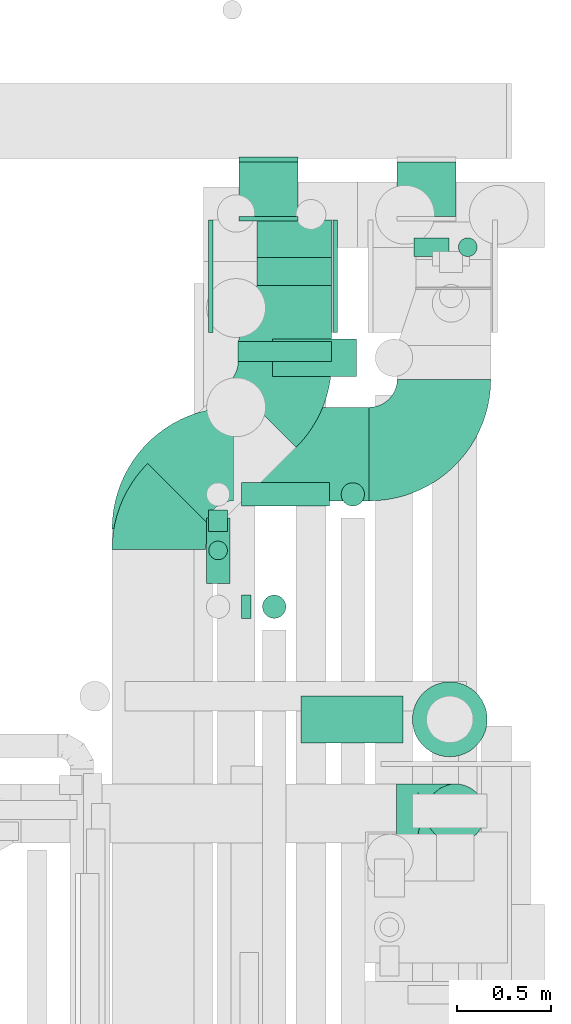
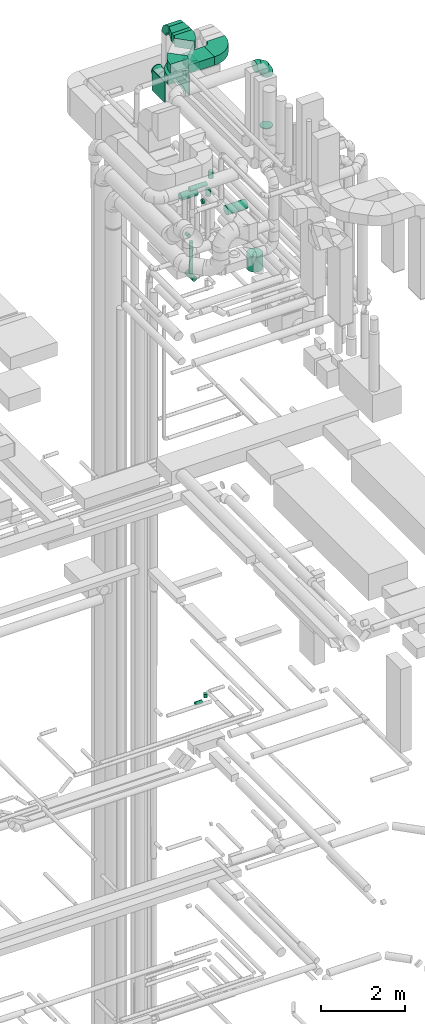
# One storey, part 311 of 337: 16 flow segments, 13 flow fittings.
"""IFC2X3 building model written with IfcOpenShell, lengths in millimetres."""

from ifc_helpers import new_model, entity, si_unit, converted_unit, derived_unit, direction, frame, frame_2d, origin, origin_2d_with_axis, place, context, subcontext, project, spatial, polyline, circle_curve, parameter, trimmed, segment, composite_curve, rectangle, circle, outline, extrude, faceted_brep, source, transform, mapped, material, type_object, type_shapes, element, save


model = new_model("IFC2X3")

# Units and contexts
model_context = context("Model", 3, precision=0.01, world=origin(), true_north=direction((6.12303176911189e-17, 1.0)))
body_context = subcontext(model_context, "Body", "Model", "MODEL_VIEW")
ifc_project = project(units=[si_unit("LENGTHUNIT", "METRE", prefix="MILLI"), si_unit("AREAUNIT", "SQUARE_METRE"), si_unit("VOLUMEUNIT", "CUBIC_METRE"), converted_unit("PLANEANGLEUNIT", "DEGREE", entity("IfcRatioMeasure", 0.0174532925199433), si_unit("PLANEANGLEUNIT", "RADIAN"), dimensions=[0, 0, 0, 0, 0, 0, 0]), si_unit("MASSUNIT", "GRAM", prefix="KILO"), derived_unit("MASSDENSITYUNIT", [(si_unit("MASSUNIT", "GRAM", prefix="KILO"), 1), (si_unit("LENGTHUNIT", "METRE"), -3)]), derived_unit("MOMENTOFINERTIAUNIT", [(si_unit("LENGTHUNIT", "METRE"), 4)]), si_unit("TIMEUNIT", "SECOND"), si_unit("FREQUENCYUNIT", "HERTZ"), si_unit("THERMODYNAMICTEMPERATUREUNIT", "DEGREE_CELSIUS"), derived_unit("THERMALTRANSMITTANCEUNIT", [(si_unit("MASSUNIT", "GRAM", prefix="KILO"), 1), (si_unit("THERMODYNAMICTEMPERATUREUNIT", "KELVIN"), -1), (si_unit("TIMEUNIT", "SECOND"), -3)]), derived_unit("VOLUMETRICFLOWRATEUNIT", [(si_unit("LENGTHUNIT", "METRE"), 3), (si_unit("TIMEUNIT", "SECOND"), -1)]), derived_unit("MASSFLOWRATEUNIT", [(si_unit("MASSUNIT", "GRAM", prefix="KILO"), 1), (si_unit("TIMEUNIT", "SECOND"), -1)]), derived_unit("ROTATIONALFREQUENCYUNIT", [(si_unit("TIMEUNIT", "SECOND"), -1)]), si_unit("ELECTRICCURRENTUNIT", "AMPERE"), si_unit("ELECTRICVOLTAGEUNIT", "VOLT"), si_unit("POWERUNIT", "WATT"), si_unit("FORCEUNIT", "NEWTON", prefix="KILO"), si_unit("ILLUMINANCEUNIT", "LUX"), si_unit("LUMINOUSFLUXUNIT", "LUMEN"), si_unit("LUMINOUSINTENSITYUNIT", "CANDELA"), derived_unit("USERDEFINED", [(si_unit("MASSUNIT", "GRAM", prefix="KILO"), -1), (si_unit("LENGTHUNIT", "METRE"), -2), (si_unit("TIMEUNIT", "SECOND"), 3), (si_unit("LUMINOUSFLUXUNIT", "LUMEN"), 1)]), derived_unit("LINEARVELOCITYUNIT", [(si_unit("LENGTHUNIT", "METRE"), 1), (si_unit("TIMEUNIT", "SECOND"), -1)]), si_unit("PRESSUREUNIT", "PASCAL"), derived_unit("USERDEFINED", [(si_unit("LENGTHUNIT", "METRE"), -2), (si_unit("MASSUNIT", "GRAM", prefix="KILO"), 1), (si_unit("TIMEUNIT", "SECOND"), -2)]), derived_unit("LINEARFORCEUNIT", [(si_unit("MASSUNIT", "GRAM", prefix="KILO"), 1), (si_unit("LENGTHUNIT", "METRE"), 1), (si_unit("TIMEUNIT", "SECOND"), -2), (si_unit("LENGTHUNIT", "METRE"), -1)]), derived_unit("PLANARFORCEUNIT", [(si_unit("MASSUNIT", "GRAM", prefix="KILO"), 1), (si_unit("LENGTHUNIT", "METRE"), 1), (si_unit("TIMEUNIT", "SECOND"), -2), (si_unit("LENGTHUNIT", "METRE"), -2)])], contexts=[model_context])

# Site, building, storey
site_placement = place(None, origin())
site = spatial("IfcSite", under=ifc_project, at=site_placement, CompositionType="ELEMENT")
building_placement = place(site_placement, origin())
building = spatial("IfcBuilding", under=site, at=building_placement, CompositionType="ELEMENT")
storey_placement = place(building_placement, origin())
storey = spatial("IfcBuildingStorey", under=building, at=storey_placement, CompositionType="ELEMENT", Elevation=0.0)

# Flow segments
duct_segment_type_1 = type_object("IfcDuctSegmentType", PredefinedType="NOTDEFINED")
flow_segment_1_placement = place(storey_placement, frame((71581.11, 15858.61, 35010.0)))
element("IfcFlowSegment", 1, at=flow_segment_1_placement, inside=storey, type_object=duct_segment_type_1, context=body_context, shape_type="SweptSolid", body=[
    extrude(rectangle(XDim=104.996866209418, YDim=499.999999999999, at=origin_2d_with_axis()), frame((250.0, 52.5, 0.0), z_axis=(0.0, 0.0, 1.0), x_axis=(0.0, 1.0, 0.0)), (0.0, 0.0, 1.0), 250.000000000004),
])
flow_segment_2_placement = place(storey_placement, frame((71557.48, 15113.0, 34600.0)))
element("IfcFlowSegment", 2, at=flow_segment_2_placement, inside=storey, type_object=duct_segment_type_1, context=body_context, shape_type="SweptSolid", body=[
    extrude(rectangle(XDim=723.625167293479, YDim=499.999999999999, at=origin_2d_with_axis()), frame((361.81, 250.0, 0.0), z_axis=(0.0, 0.0, 1.0), x_axis=(-1.0, 0.0, 0.0)), (0.0, 0.0, 1.0), 250.000000000004),
])
duct_segment_type_2 = type_object("IfcDuctSegmentType", PredefinedType="NOTDEFINED")
flow_segment_3_placement = place(storey_placement, frame((72519.33, 16416.98, 14995.4)))
element("IfcFlowSegment", 3, at=flow_segment_3_placement, inside=storey, type_object=duct_segment_type_2, context=body_context, shape_type="SweptSolid", body=[
    extrude(circle(Radius=50.0, at=origin_2d_with_axis()), frame((0.0, 51.6, 51.6), z_axis=(1.0, 0.0, 0.0), x_axis=(0.0, 1.0, 0.0)), (0.0, 0.0, 1.0), 188.24102220654),
])
flow_segment_4_placement = place(storey_placement, frame((72755.98, 16416.98, 15147.0)))
element("IfcFlowSegment", 4, at=flow_segment_4_placement, inside=storey, type_object=duct_segment_type_2, context=body_context, shape_type="SweptSolid", body=[
    extrude(circle(Radius=50.0, at=origin_2d_with_axis()), frame((51.6, 51.6, 0.0), z_axis=(0.0, 0.0, 1.0), x_axis=(0.0, 1.0, 0.0)), (0.0, 0.0, 1.0), 103.000000000003),
])
flow_segment_5_placement = place(storey_placement, frame((71583.06, 16633.61, 33390.9)))
element("IfcFlowSegment", 5, at=flow_segment_5_placement, inside=storey, type_object=duct_segment_type_2, context=body_context, shape_type="SweptSolid", body=[
    extrude(circle(Radius=157.5, at=origin_2d_with_axis()), frame((159.1, 0.0, 159.1), z_axis=(0.0, 1.0, 0.0), x_axis=(1.0, 0.0, 0.0)), (0.0, 0.0, 1.0), 289.999999999986),
])
flow_segment_6_placement = place(storey_placement, frame((72427.44, 16633.61, 33390.9)))
element("IfcFlowSegment", 6, at=flow_segment_6_placement, inside=storey, type_object=duct_segment_type_2, context=body_context, shape_type="SweptSolid", body=[
    extrude(circle(Radius=157.5, at=origin_2d_with_axis()), frame((159.1, 0.0, 159.1), z_axis=(0.0, 1.0, 0.0), x_axis=(1.0, 0.0, 0.0)), (0.0, 0.0, 1.0), 289.999999999977),
])
flow_segment_7_placement = place(storey_placement, frame((71916.81, 13819.26, 31073.4)))
element("IfcFlowSegment", 7, at=flow_segment_7_placement, inside=storey, type_object=duct_segment_type_2, context=body_context, shape_type="SweptSolid", body=[
    extrude(circle(Radius=125.0, at=origin_2d_with_axis()), frame((0.0, 126.6, 126.6), z_axis=(1.0, 0.0, 0.0), x_axis=(0.0, -1.0, 0.0)), (0.0, 0.0, 1.0), 545.000000000041),
])
flow_segment_8_placement = place(storey_placement, frame((72129.7, 15083.65, 31325.0)))
element("IfcFlowSegment", 8, at=flow_segment_8_placement, inside=storey, type_object=duct_segment_type_2, context=body_context, shape_type="SweptSolid", body=[
    extrude(circle(Radius=62.5, at=origin_2d_with_axis()), frame((64.1, 64.1, 0.0), z_axis=(0.0, 0.0, 1.0), x_axis=(-1.0, 0.0, 0.0)), (0.0, 0.0, 1.0), 199.999999999994),
])
flow_segment_9_placement = place(storey_placement, frame((71598.8, 15083.65, 31135.9)))
element("IfcFlowSegment", 9, at=flow_segment_9_placement, inside=storey, type_object=duct_segment_type_2, context=body_context, shape_type="SweptSolid", body=[
    extrude(circle(Radius=62.5, at=origin_2d_with_axis()), frame((0.0, 64.1, 64.1), z_axis=(1.0, 0.0, 0.0), x_axis=(0.0, 1.0, 0.0)), (0.0, 0.0, 1.0), 470.000000000014),
])
flow_segment_10_placement = place(storey_placement, frame((71409.7, 14672.75, 28835.9)))
element("IfcFlowSegment", 10, at=flow_segment_10_placement, inside=storey, type_object=duct_segment_type_2, context=body_context, shape_type="SweptSolid", body=[
    extrude(circle(Radius=62.5, at=origin_2d_with_axis()), frame((64.1, 0.0, 64.1), z_axis=(0.0, 1.0, 0.0), x_axis=(-1.0, 0.0, 0.0)), (0.0, 0.0, 1.0), 350.000000000018),
])
flow_segment_11_placement = place(storey_placement, frame((71598.8, 14483.65, 31135.9)))
element("IfcFlowSegment", 11, at=flow_segment_11_placement, inside=storey, type_object=duct_segment_type_2, context=body_context, shape_type="SweptSolid", body=[
    extrude(circle(Radius=62.5, at=origin_2d_with_axis()), frame((0.0, 64.1, 64.1), z_axis=(1.0, 0.0, 0.0), x_axis=(0.0, -1.0, 0.0)), (0.0, 0.0, 1.0), 50.0000000000146),
])
flow_segment_12_placement = place(storey_placement, frame((71709.7, 14483.65, 31325.0)))
element("IfcFlowSegment", 12, at=flow_segment_12_placement, inside=storey, type_object=duct_segment_type_2, context=body_context, shape_type="SweptSolid", body=[
    extrude(circle(Radius=62.5, at=origin_2d_with_axis()), frame((64.1, 64.1, 0.0), z_axis=(0.0, 0.0, 1.0), x_axis=(0.0, -1.0, 0.0)), (0.0, 0.0, 1.0), 189.999999999991),
])
flow_segment_13_placement = place(storey_placement, frame((72510.22, 13744.26, 29250.0)))
element("IfcFlowSegment", 13, at=flow_segment_13_placement, inside=storey, type_object=duct_segment_type_2, context=body_context, shape_type="SweptSolid", body=[
    extrude(circle(Radius=200.0, at=origin_2d_with_axis()), frame((201.6, 201.6, 0.0), z_axis=(0.0, 0.0, 1.0), x_axis=(0.0, -1.0, 0.0)), (0.0, 0.0, 1.0), 440.000000000026),
])
flow_segment_14_placement = place(storey_placement, frame((71422.2, 14796.98, 28982.5)))
element("IfcFlowSegment", 14, at=flow_segment_14_placement, inside=storey, type_object=duct_segment_type_2, context=body_context, shape_type="SweptSolid", body=[
    extrude(circle(Radius=50.0, at=origin_2d_with_axis()), frame((51.6, 51.6, 0.0), z_axis=(0.0, 0.0, 1.0), x_axis=(0.0, 1.0, 0.0)), (0.0, 0.0, 1.0), 917.499999999921),
])
flow_segment_15_placement = place(storey_placement, frame((71422.2, 14948.58, 29948.4)))
element("IfcFlowSegment", 15, at=flow_segment_15_placement, inside=storey, type_object=duct_segment_type_2, context=body_context, shape_type="SweptSolid", body=[
    extrude(circle(Radius=50.0, at=origin_2d_with_axis()), frame((51.6, 0.0, 51.6), z_axis=(0.0, 1.0, 0.0), x_axis=(-1.0, 0.0, 0.0)), (0.0, 0.0, 1.0), 116.667364066058),
])
flow_segment_16_placement = place(storey_placement, frame((71765.11, 15776.15, 30373.4)))
element("IfcFlowSegment", 16, at=flow_segment_16_placement, inside=storey, type_object=duct_segment_type_2, context=body_context, shape_type="SweptSolid", body=[
    extrude(circle(Radius=100.0, at=origin_2d_with_axis()), frame((0.0, 101.6, 101.6), z_axis=(1.0, 0.0, 0.0), x_axis=(0.0, 1.0, 0.0)), (0.0, 0.0, 1.0), 448.687977067073),
])

# Flow fittings
ifc_material = material()
duct_fitting_type_1 = type_object("IfcDuctFittingType", PredefinedType="NOTDEFINED", material=ifc_material)
shared_shape_1 = source(origin(), body_context, "Body", "SweptSolid", [
    extrude(rectangle(XDim=200.0, YDim=26.096, at=origin_2d_with_axis()), frame((6.95, 0.0, -200.0), z_axis=(0.0, 0.0, 1.0), x_axis=(0.0, -1.0, 0.0)), (0.0, 0.0, 1.0), 400.0),
])
type_shapes(duct_fitting_type_1, [shared_shape_1])
flow_fitting_1_placement = place(storey_placement, frame((71881.11, 16513.61, 33850.0), z_axis=(1.0, 0.0, 0.0), x_axis=(0.0, 0.0, 1.0)))
element("IfcFlowFitting", 17, at=flow_fitting_1_placement, inside=storey, type_object=duct_fitting_type_1, material=ifc_material, context=body_context, shape_type="MappedRepresentation", body=[
    mapped(shared_shape_1, transform((0.0, 0.0, 0.0), scale=1.0)),
])
duct_fitting_type_2 = type_object("IfcDuctFittingType", PredefinedType="NOTDEFINED", material=ifc_material)
shared_shape_2 = source(origin(), body_context, "Body", "SweptSolid", [
    extrude(rectangle(XDim=24.9999999999999, YDim=600.0, at=origin_2d_with_axis()), frame((12.5, 0.0, -300.0)), (0.0, 0.0, 1.0), 600.0),
])
type_shapes(duct_fitting_type_2, [shared_shape_2])
flow_fitting_2_placement = place(storey_placement, frame((72087.1, 16313.61, 33550.0)))
element("IfcFlowFitting", 18, at=flow_fitting_2_placement, inside=storey, type_object=duct_fitting_type_2, material=ifc_material, context=body_context, shape_type="MappedRepresentation", body=[
    mapped(shared_shape_2, transform((0.0, 0.0, 0.0), scale=1.0)),
])
flow_fitting_3_placement = place(storey_placement, frame((71447.1, 16313.61, 33550.0), z_axis=(0.0, 0.0, 1.0), x_axis=(-1.0, 0.0, 0.0)))
element("IfcFlowFitting", 19, at=flow_fitting_3_placement, inside=storey, type_object=duct_fitting_type_2, material=ifc_material, context=body_context, shape_type="MappedRepresentation", body=[
    mapped(shared_shape_2, transform((0.0, 0.0, 0.0), scale=1.0)),
])
duct_fitting_type_3 = type_object("IfcDuctFittingType", PredefinedType="NOTDEFINED", material=ifc_material)
shared_shape_3 = source(origin(), body_context, "Body", "Brep", [
    faceted_brep([(-315.0, 0.0, -157.5), (-315.0, -40.76, -152.13), (-315.0, -78.75, -136.4), (-315.0, -111.37, -111.37), (-315.0, -136.4, -78.75), (-315.0, -152.13, -40.76), (-315.0, -157.5, 0.0), (-315.0, -152.13, 40.76), (-315.0, -136.4, 78.75), (-315.0, -111.37, 111.37), (-315.0, -78.75, 136.4), (-315.0, -40.76, 152.13), (-315.0, 0.0, 157.5), (-315.0, 40.76, 152.13), (-315.0, 78.75, 136.4), (-315.0, 111.37, 111.37), (-315.0, 136.4, 78.75), (-315.0, 152.13, 40.76), (-315.0, 157.5, 0.0), (-315.0, 152.13, -40.76), (-315.0, 136.4, -78.75), (-315.0, 111.37, -111.37), (-315.0, 78.75, -136.4), (-315.0, 40.76, -152.13), (-241.52, 40.76, 152.13), (-251.7, 78.75, 136.4), (-230.6, 0.0, 157.5), (-260.44, 111.37, 111.37), (-271.36, 152.13, 40.76), (-272.8, 157.5, 0.0), (-267.14, 136.4, 78.75), (-267.14, 136.4, -78.75), (-260.44, 111.37, -111.37), (-271.36, 152.13, -40.76), (-241.52, 40.76, -152.13), (-230.6, 0.0, -157.5), (-251.7, 78.75, -136.4), (-219.67, -40.76, -152.13), (-209.5, -78.75, -136.4), (-200.75, -111.37, -111.37), (-194.05, -136.4, -78.75), (-189.83, -152.13, -40.76), (-188.39, -157.5, 0.0), (-189.83, -152.13, 40.76), (-194.05, -136.4, 78.75), (-200.75, -111.37, 111.37), (-209.5, -78.75, 136.4), (-219.67, -40.76, 152.13), (-114.25, 114.25, 152.13), (-142.05, 142.05, 136.4), (-84.4, 84.4, 157.5), (-165.93, 165.93, 111.37), (-184.25, 184.25, 78.75), (-195.77, 195.77, 40.76), (-199.7, 199.7, 0.0), (-195.77, 195.77, -40.76), (-184.25, 184.25, -78.75), (-165.93, 165.93, -111.37), (-114.25, 114.25, -152.13), (-84.4, 84.4, -157.5), (-142.05, 142.05, -136.4), (-54.56, 54.56, -152.13), (-26.75, 26.75, -136.4), (-2.88, 2.88, -111.37), (15.45, -15.45, -78.75), (26.97, -26.97, -40.76), (30.89, -30.89, 0.0), (26.97, -26.97, 40.76), (15.45, -15.45, 78.75), (-2.88, 2.88, 111.37), (-26.75, 26.75, 136.4), (-54.56, 54.56, 152.13), (-40.76, 241.52, 152.13), (-78.75, 251.7, 136.4), (0.0, 230.6, 157.5), (-111.37, 260.44, 111.37), (-136.4, 267.14, 78.75), (-152.13, 271.36, 40.76), (-157.5, 272.8, 0.0), (-152.13, 271.36, -40.76), (-136.4, 267.14, -78.75), (-111.37, 260.44, -111.37), (-40.76, 241.52, -152.13), (0.0, 230.6, -157.5), (-78.75, 251.7, -136.4), (40.76, 219.67, -152.13), (78.75, 209.5, -136.4), (111.37, 200.75, -111.37), (136.4, 194.05, -78.75), (152.13, 189.83, -40.76), (157.5, 188.39, 0.0), (152.13, 189.83, 40.76), (136.4, 194.05, 78.75), (111.37, 200.75, 111.37), (78.75, 209.5, 136.4), (40.76, 219.67, 152.13), (-40.76, 315.0, -152.13), (-78.75, 315.0, -136.4), (-111.37, 315.0, -111.37), (-136.4, 315.0, -78.75), (-152.13, 315.0, -40.76), (-157.5, 315.0, 0.0), (-152.13, 315.0, 40.76), (-136.4, 315.0, 78.75), (-111.37, 315.0, 111.37), (-78.75, 315.0, 136.4), (-40.76, 315.0, 152.13), (0.0, 315.0, 157.5), (40.76, 315.0, 152.13), (78.75, 315.0, 136.4), (111.37, 315.0, 111.37), (136.4, 315.0, 78.75), (152.13, 315.0, 40.76), (157.5, 315.0, 0.0), (152.13, 315.0, -40.76), (136.4, 315.0, -78.75), (111.37, 315.0, -111.37), (78.75, 315.0, -136.4), (40.76, 315.0, -152.13), (0.0, 315.0, -157.5)], [[[0, 1, 2, 3, 4, 5, 6, 7, 8, 9, 10, 11, 12, 13, 14, 15, 16, 17, 18, 19, 20, 21, 22, 23]], [[24, 25, 14, 13]], [[26, 24, 13, 12]], [[14, 25, 27, 15]], [[28, 29, 18, 17]], [[30, 28, 17, 16]], [[15, 27, 30, 16]], [[20, 31, 32, 21]], [[33, 31, 20, 19]], [[18, 29, 33, 19]], [[34, 35, 0, 23]], [[36, 34, 23, 22]], [[32, 36, 22, 21]], [[1, 0, 35, 37]], [[2, 1, 37, 38]], [[38, 39, 3, 2]], [[5, 4, 40, 41]], [[6, 5, 41, 42]], [[39, 40, 4, 3]], [[6, 42, 43, 7]], [[7, 43, 44, 8]], [[8, 44, 45, 9]], [[9, 45, 46, 10]], [[10, 46, 47, 11]], [[26, 12, 11, 47]], [[48, 49, 25, 24]], [[50, 48, 24, 26]], [[27, 25, 49, 51]], [[52, 53, 28, 30]], [[51, 52, 30, 27]], [[29, 28, 53, 54]], [[55, 56, 31, 33]], [[54, 55, 33, 29]], [[32, 31, 56, 57]], [[58, 59, 35, 34]], [[60, 58, 34, 36]], [[57, 60, 36, 32]], [[37, 35, 59, 61]], [[38, 37, 61, 62]], [[39, 38, 62, 63]], [[41, 40, 64, 65]], [[42, 41, 65, 66]], [[63, 64, 40, 39]], [[43, 42, 66, 67]], [[44, 43, 67, 68]], [[68, 69, 45, 44]], [[46, 45, 69, 70]], [[47, 46, 70, 71]], [[26, 47, 71, 50]], [[72, 73, 49, 48]], [[74, 72, 48, 50]], [[51, 49, 73, 75]], [[76, 77, 53, 52]], [[75, 76, 52, 51]], [[54, 53, 77, 78]], [[79, 80, 56, 55]], [[78, 79, 55, 54]], [[57, 56, 80, 81]], [[82, 83, 59, 58]], [[84, 82, 58, 60]], [[81, 84, 60, 57]], [[61, 59, 83, 85]], [[62, 61, 85, 86]], [[63, 62, 86, 87]], [[65, 64, 88, 89]], [[66, 65, 89, 90]], [[87, 88, 64, 63]], [[67, 66, 90, 91]], [[68, 67, 91, 92]], [[92, 93, 69, 68]], [[70, 69, 93, 94]], [[71, 70, 94, 95]], [[50, 71, 95, 74]], [[96, 97, 98, 99, 100, 101, 102, 103, 104, 105, 106, 107, 108, 109, 110, 111, 112, 113, 114, 115, 116, 117, 118, 119]], [[106, 105, 73, 72]], [[107, 106, 72, 74]], [[75, 73, 105, 104]], [[77, 76, 103, 102]], [[78, 77, 102, 101]], [[104, 103, 76, 75]], [[78, 101, 100, 79]], [[79, 100, 99, 80]], [[98, 81, 80, 99]], [[84, 97, 96, 82]], [[82, 96, 119, 83]], [[97, 84, 81, 98]], [[83, 119, 118, 85]], [[85, 118, 117, 86]], [[116, 87, 86, 117]], [[88, 115, 114, 89]], [[89, 114, 113, 90]], [[115, 88, 87, 116]], [[91, 90, 113, 112]], [[92, 91, 112, 111]], [[111, 110, 93, 92]], [[95, 94, 109, 108]], [[74, 95, 108, 107]], [[110, 109, 94, 93]]]),
])
type_shapes(duct_fitting_type_3, [shared_shape_3])
flow_fitting_4_placement = place(storey_placement, frame((72743.11, 13443.57, 35520.0), z_axis=(0.0, 1.0, 0.0), x_axis=(1.0, 0.0, 0.0)))
element("IfcFlowFitting", 20, at=flow_fitting_4_placement, inside=storey, type_object=duct_fitting_type_3, material=ifc_material, context=body_context, shape_type="MappedRepresentation", body=[
    mapped(shared_shape_3, transform((0.0, 0.0, 0.0), scale=1.0)),
])
duct_fitting_type_4 = type_object("IfcDuctFittingType", PredefinedType="NOTDEFINED", material=ifc_material)
shared_shape_4 = source(origin(), body_context, "Body", "Brep", [
    faceted_brep([(20.0, 40.76, -152.13), (20.0, 78.75, -136.4), (20.0, 111.37, -111.37), (20.0, 136.4, -78.75), (20.0, 152.13, -40.76), (20.0, 157.5, 0.0), (20.0, 152.13, 40.76), (20.0, 136.4, 78.75), (20.0, 111.37, 111.37), (20.0, 78.75, 136.4), (20.0, 40.76, 152.13), (20.0, 0.0, 157.5), (20.0, -40.76, 152.13), (20.0, -78.75, 136.4), (20.0, -111.37, 111.37), (20.0, -136.4, 78.75), (20.0, -152.13, 40.76), (20.0, -157.5, 0.0), (20.0, -152.13, -40.76), (20.0, -136.4, -78.75), (20.0, -111.37, -111.37), (20.0, -78.75, -136.4), (20.0, -40.76, -152.13), (20.0, 0.0, -157.5), (0.0, 0.0, 157.5), (0.0, 40.76, 152.13), (-6.1, 40.76, 152.13), (-6.1, 0.0, 157.5), (0.0, 78.75, 136.4), (-6.1, 78.75, 136.4), (0.0, 111.37, 111.37), (-6.1, 111.37, 111.37), (0.0, 136.4, 78.75), (0.0, 152.13, 40.76), (-6.1, 152.13, 40.76), (-6.1, 136.4, 78.75), (0.0, 157.5, 0.0), (-6.1, 157.5, 0.0), (0.0, 152.13, -40.76), (-6.1, 152.13, -40.76), (0.0, 136.4, -78.75), (-6.1, 136.4, -78.75), (0.0, 111.37, -111.37), (-6.1, 111.37, -111.37), (0.0, 0.0, -157.5), (-6.1, 0.0, -157.5), (-6.1, 40.76, -152.13), (0.0, 40.76, -152.13), (-6.1, 78.75, -136.4), (0.0, 78.75, -136.4), (0.0, -40.76, -152.13), (-6.1, -40.76, -152.13), (0.0, -78.75, -136.4), (-6.1, -78.75, -136.4), (0.0, -111.37, -111.37), (-6.1, -111.37, -111.37), (0.0, -136.4, -78.75), (0.0, -152.13, -40.76), (-6.1, -152.13, -40.76), (-6.1, -136.4, -78.75), (0.0, -157.5, 0.0), (-6.1, -157.5, 0.0), (0.0, -152.13, 40.76), (-6.1, -152.13, 40.76), (0.0, -136.4, 78.75), (-6.1, -136.4, 78.75), (0.0, -111.37, 111.37), (-6.1, -111.37, 111.37), (0.0, -78.75, 136.4), (0.0, -40.76, 152.13), (-6.1, -40.76, 152.13), (-6.1, -78.75, 136.4)], [[[0, 1, 2, 3, 4, 5, 6, 7, 8, 9, 10, 11, 12, 13, 14, 15, 16, 17, 18, 19, 20, 21, 22, 23]], [[24, 11, 10, 25, 26, 27]], [[25, 10, 9, 28, 29, 26]], [[28, 9, 8, 30, 31, 29]], [[32, 7, 6, 33, 34, 35]], [[33, 6, 5, 36, 37, 34]], [[30, 8, 7, 32, 35, 31]], [[36, 5, 4, 38, 39, 37]], [[38, 4, 3, 40, 41, 39]], [[40, 3, 2, 42, 43, 41]], [[0, 23, 44, 45, 46, 47]], [[1, 0, 47, 46, 48, 49]], [[49, 48, 43, 42, 2, 1]], [[44, 23, 22, 50, 51, 45]], [[50, 22, 21, 52, 53, 51]], [[52, 21, 20, 54, 55, 53]], [[56, 19, 18, 57, 58, 59]], [[57, 18, 17, 60, 61, 58]], [[54, 20, 19, 56, 59, 55]], [[60, 17, 16, 62, 63, 61]], [[62, 16, 15, 64, 65, 63]], [[64, 15, 14, 66, 67, 65]], [[68, 13, 12, 69, 70, 71]], [[69, 12, 11, 24, 27, 70]], [[66, 14, 13, 68, 71, 67]], [[45, 51, 53, 55, 59, 58, 61, 63, 65, 67, 71, 70, 27, 26, 29, 31, 35, 34, 37, 39, 41, 43, 48, 46]]]),
])
type_shapes(duct_fitting_type_4, [shared_shape_4])
flow_fitting_5_placement = place(storey_placement, frame((71742.15, 16943.61, 33550.0), z_axis=(0.0, 0.0, -1.0), x_axis=(0.0, -1.0, 0.0)))
element("IfcFlowFitting", 21, at=flow_fitting_5_placement, inside=storey, type_object=duct_fitting_type_4, material=ifc_material, context=body_context, shape_type="MappedRepresentation", body=[
    mapped(shared_shape_4, transform((0.0, 0.0, 0.0), scale=1.0)),
])
duct_fitting_type_5 = type_object("IfcDuctFittingType", PredefinedType="NOTDEFINED", material=ifc_material)
shared_shape_5 = source(origin(), body_context, "Body", "Brep", [
    faceted_brep([(20.0, 0.0, -157.5), (20.0, 40.76, -152.13), (20.0, 78.75, -136.4), (20.0, 111.37, -111.37), (20.0, 136.4, -78.75), (20.0, 152.13, -40.76), (20.0, 157.5, 0.0), (20.0, 152.13, 40.76), (20.0, 136.4, 78.75), (20.0, 111.37, 111.37), (20.0, 78.75, 136.4), (20.0, 40.76, 152.13), (20.0, 0.0, 157.5), (20.0, -40.76, 152.13), (20.0, -78.75, 136.4), (20.0, -111.37, 111.37), (20.0, -136.4, 78.75), (20.0, -152.13, 40.76), (20.0, -157.5, 0.0), (20.0, -152.13, -40.76), (20.0, -136.4, -78.75), (20.0, -111.37, -111.37), (20.0, -78.75, -136.4), (20.0, -40.76, -152.13), (0.0, 0.0, 157.5), (-6.1, 0.0, 157.5), (-6.1, -40.76, 152.13), (0.0, -40.76, 152.13), (-6.1, -78.75, 136.4), (0.0, -78.75, 136.4), (0.0, -111.37, 111.37), (-6.1, -111.37, 111.37), (0.0, -136.4, 78.75), (-6.1, -136.4, 78.75), (-6.1, -152.13, 40.76), (0.0, -152.13, 40.76), (-6.1, -157.5, 0.0), (0.0, -157.5, 0.0), (-6.1, -152.13, -40.76), (0.0, -152.13, -40.76), (-6.1, -136.4, -78.75), (0.0, -136.4, -78.75), (0.0, -111.37, -111.37), (-6.1, -111.37, -111.37), (0.0, 0.0, -157.5), (0.0, -40.76, -152.13), (-6.1, -40.76, -152.13), (-6.1, 0.0, -157.5), (0.0, -78.75, -136.4), (-6.1, -78.75, -136.4), (-6.1, 40.76, -152.13), (0.0, 40.76, -152.13), (-6.1, 78.75, -136.4), (0.0, 78.75, -136.4), (0.0, 111.37, -111.37), (-6.1, 111.37, -111.37), (0.0, 136.4, -78.75), (-6.1, 136.4, -78.75), (-6.1, 152.13, -40.76), (0.0, 152.13, -40.76), (-6.1, 157.5, 0.0), (0.0, 157.5, 0.0), (-6.1, 152.13, 40.76), (0.0, 152.13, 40.76), (-6.1, 136.4, 78.75), (0.0, 136.4, 78.75), (0.0, 111.37, 111.37), (-6.1, 111.37, 111.37), (0.0, 78.75, 136.4), (-6.1, 78.75, 136.4), (-6.1, 40.76, 152.13), (0.0, 40.76, 152.13)], [[[0, 1, 2, 3, 4, 5, 6, 7, 8, 9, 10, 11, 12, 13, 14, 15, 16, 17, 18, 19, 20, 21, 22, 23]], [[13, 12, 24, 25, 26, 27]], [[14, 13, 27, 26, 28, 29]], [[30, 15, 14, 29, 28, 31]], [[17, 16, 32, 33, 34, 35]], [[18, 17, 35, 34, 36, 37]], [[32, 16, 15, 30, 31, 33]], [[19, 18, 37, 36, 38, 39]], [[20, 19, 39, 38, 40, 41]], [[42, 21, 20, 41, 40, 43]], [[44, 0, 23, 45, 46, 47]], [[48, 49, 46, 45, 23, 22]], [[22, 21, 42, 43, 49, 48]], [[1, 0, 44, 47, 50, 51]], [[2, 1, 51, 50, 52, 53]], [[54, 3, 2, 53, 52, 55]], [[5, 4, 56, 57, 58, 59]], [[6, 5, 59, 58, 60, 61]], [[56, 4, 3, 54, 55, 57]], [[7, 6, 61, 60, 62, 63]], [[8, 7, 63, 62, 64, 65]], [[66, 9, 8, 65, 64, 67]], [[11, 10, 68, 69, 70, 71]], [[12, 11, 71, 70, 25, 24]], [[68, 10, 9, 66, 67, 69]], [[46, 49, 43, 40, 38, 36, 34, 33, 31, 28, 26, 25, 70, 69, 67, 64, 62, 60, 58, 57, 55, 52, 50, 47]]]),
])
type_shapes(duct_fitting_type_5, [shared_shape_5])
for number, where, z_axis, x_axis in (
    (22, (71742.15, 16613.61, 33550.0), (0.0, 0.0, -1.0), (0.0, 1.0, 0.0)),
    (23, (72743.11, 13443.57, 33696.26), (0.0, 1.0, 0.0), (0.0, 0.0, 1.0)),
):
    element("IfcFlowFitting", number, at=place(storey_placement, frame(where, z_axis=z_axis, x_axis=x_axis)), inside=storey, type_object=duct_fitting_type_5, material=ifc_material, context=body_context, shape_type="MappedRepresentation", body=[
        mapped(shared_shape_5, transform((0.0, 0.0, 0.0), scale=1.0)),
    ])
duct_fitting_type_6 = type_object("IfcDuctFittingType", PredefinedType="NOTDEFINED", material=ifc_material)
shared_shape_6 = source(origin(), body_context, "Body", "Brep", [
    faceted_brep([(300.0, -250.0, 100.0), (300.0, -250.0, -100.0), (300.0, 150.0, -100.0), (300.0, 150.0, 100.0), (0.0, -250.0, 125.0), (0.0, 250.0, 125.0), (0.0, 250.0, -125.0), (0.0, -250.0, -125.0)], [[[0, 1, 2, 3]], [[4, 5, 6, 7]], [[4, 7, 1, 0]], [[7, 6, 2, 1]], [[6, 5, 3, 2]], [[5, 4, 0, 3]]]),
])
type_shapes(duct_fitting_type_6, [shared_shape_6])
flow_fitting_6_placement = place(storey_placement, frame((71831.11, 15963.61, 35135.0), z_axis=(0.0, 0.0, 1.0), x_axis=(0.0, 1.0, 0.0)))
element("IfcFlowFitting", 24, at=flow_fitting_6_placement, inside=storey, type_object=duct_fitting_type_6, material=ifc_material, context=body_context, shape_type="MappedRepresentation", body=[
    mapped(shared_shape_6, transform((0.0, 0.0, 0.0), scale=1.0)),
])
duct_fitting_type_7 = type_object("IfcDuctFittingType", PredefinedType="NOTDEFINED", material=ifc_material)
shared_shape_7 = source(origin(), body_context, "Body", "SweptSolid", [
    extrude(outline(composite_curve([segment(polyline([(-450.0, -200.0), (50.0, -200.0)]), True, "CONTINUOUS"), segment(trimmed(circle_curve(frame_2d((200.0, -200.0), x_axis=(0.0, 1.0)), 150.0), [parameter(0.0)], [parameter(90.0000000000001)], True, "PARAMETER"), False, "CONTINUOUS"), segment(polyline([(200.0, -50.0), (200.0, 450.0)]), True, "CONTINUOUS"), segment(trimmed(circle_curve(frame_2d((200.0, -200.0), x_axis=(0.0, 1.0)), 650.0), [parameter(0.0)], [parameter(90.0000000000001)], True, "PARAMETER"), True, "CONTINUOUS")], self_intersect=False)), frame((-200.0, 200.0, -125.0), z_axis=(0.0, 0.0, 1.0), x_axis=(-1.0, 0.0, 0.0)), (0.0, 0.0, 1.0), 250.0),
])
type_shapes(duct_fitting_type_7, [shared_shape_7])
flow_fitting_7_placement = place(storey_placement, frame((71157.48, 15363.0, 34725.0), z_axis=(0.0, 0.0, 1.0), x_axis=(-1.0, 0.0, 0.0)))
element("IfcFlowFitting", 25, at=flow_fitting_7_placement, inside=storey, type_object=duct_fitting_type_7, material=ifc_material, context=body_context, shape_type="MappedRepresentation", body=[
    mapped(shared_shape_7, transform((0.0, 0.0, 0.0), scale=1.0)),
])
flow_fitting_8_placement = place(storey_placement, frame((72681.11, 15363.0, 34725.0)))
element("IfcFlowFitting", 26, at=flow_fitting_8_placement, inside=storey, type_object=duct_fitting_type_7, material=ifc_material, context=body_context, shape_type="MappedRepresentation", body=[
    mapped(shared_shape_7, transform((0.0, 0.0, 0.0), scale=1.0)),
])
duct_fitting_type_8 = type_object("IfcDuctFittingType", PredefinedType="NOTDEFINED", material=ifc_material)
shared_shape_8 = source(origin(), body_context, "Body", "SweptSolid", [
    extrude(outline(composite_curve([segment(polyline([(-308.58, -141.42), (191.42, -141.42)]), True, "CONTINUOUS"), segment(trimmed(circle_curve(frame_2d((341.42, -141.42), x_axis=(-0.707106781186553, 0.707106781186546)), 150.0), [parameter(0.0)], [parameter(45.0)], True, "PARAMETER"), False, "CONTINUOUS"), segment(polyline([(235.36, -35.36), (-118.2, 318.2)]), True, "CONTINUOUS"), segment(trimmed(circle_curve(frame_2d((341.42, -141.42), x_axis=(-0.707106781186553, 0.707106781186546)), 650.0), [parameter(0.0)], [parameter(45.0)], True, "PARAMETER"), True, "CONTINUOUS")], self_intersect=False)), frame((-24.26, 58.58, -125.0), z_axis=(0.0, 0.0, 1.0), x_axis=(-0.707106781186547, 0.707106781186548, 0.0)), (0.0, 0.0, 1.0), 250.0),
])
type_shapes(duct_fitting_type_8, [shared_shape_8])
for number, where, z_axis, x_axis in (
    (27, (71157.48, 15019.3, 35135.0), (0.0, 0.0, 1.0), (-0.707106781186561, -0.707106781186534, 0.0)),
    (28, (71831.11, 15692.93, 35135.0), (0.0, 0.0, 1.0), (0.707106781186574, 0.707106781186521, 0.0)),
):
    element("IfcFlowFitting", number, at=place(storey_placement, frame(where, z_axis=z_axis, x_axis=x_axis)), inside=storey, type_object=duct_fitting_type_8, material=ifc_material, context=body_context, shape_type="MappedRepresentation", body=[
        mapped(shared_shape_8, transform((0.0, 0.0, 0.0), scale=1.0)),
    ])
duct_fitting_type_9 = type_object("IfcDuctFittingType", PredefinedType="NOTDEFINED", material=ifc_material)
shared_shape_9 = source(origin(), body_context, "Body", "SweptSolid", [
    extrude(outline(composite_curve([segment(polyline([(-225.0, -125.0), (-25.0, -125.0)]), True, "CONTINUOUS"), segment(trimmed(circle_curve(frame_2d((125.0, -125.0), x_axis=(0.0, 1.0)), 150.0), [parameter(0.0)], [parameter(90.0000000000001)], True, "PARAMETER"), False, "CONTINUOUS"), segment(polyline([(125.0, 25.0), (125.0, 225.0)]), True, "CONTINUOUS"), segment(trimmed(circle_curve(frame_2d((125.0, -125.0), x_axis=(0.0, 1.0)), 350.0), [parameter(0.0)], [parameter(90.0000000000001)], True, "PARAMETER"), True, "CONTINUOUS")], self_intersect=False)), frame((-125.0, 125.0, -200.0), z_axis=(0.0, 0.0, 1.0), x_axis=(-1.0, 0.0, 0.0)), (0.0, 0.0, 1.0), 400.0),
])
type_shapes(duct_fitting_type_9, [shared_shape_9])
flow_fitting_9_placement = place(storey_placement, frame((71881.11, 16513.61, 35135.0), z_axis=(-1.0, 0.0, 0.0), x_axis=(0.0, 1.0, 0.0)))
element("IfcFlowFitting", 29, at=flow_fitting_9_placement, inside=storey, type_object=duct_fitting_type_9, material=ifc_material, context=body_context, shape_type="MappedRepresentation", body=[
    mapped(shared_shape_9, transform((0.0, 0.0, 0.0), scale=1.0)),
])

save(model, "model.ifc")
